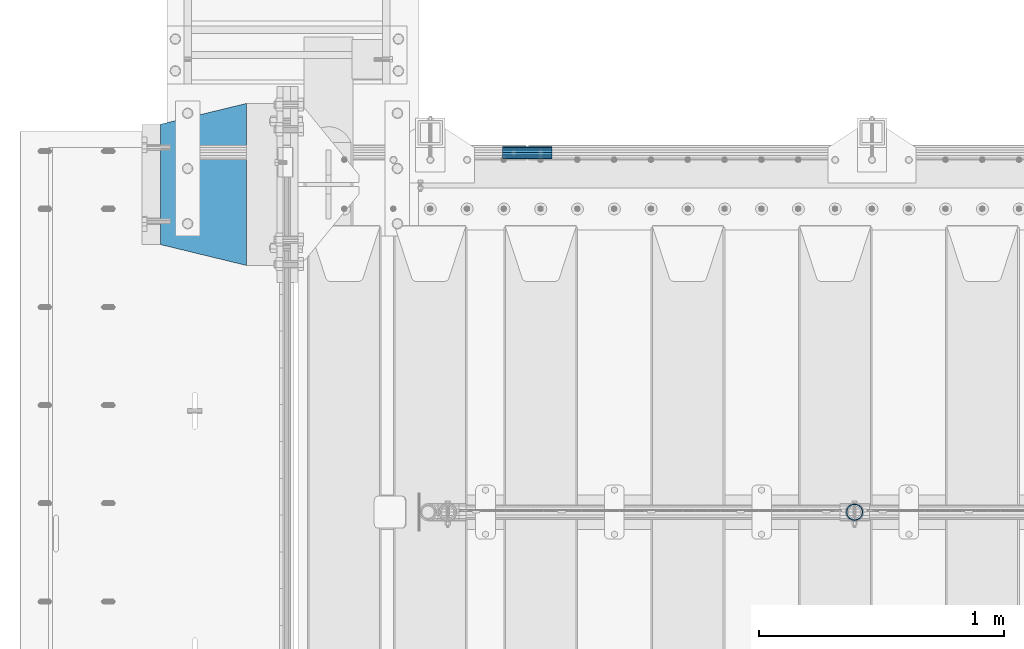
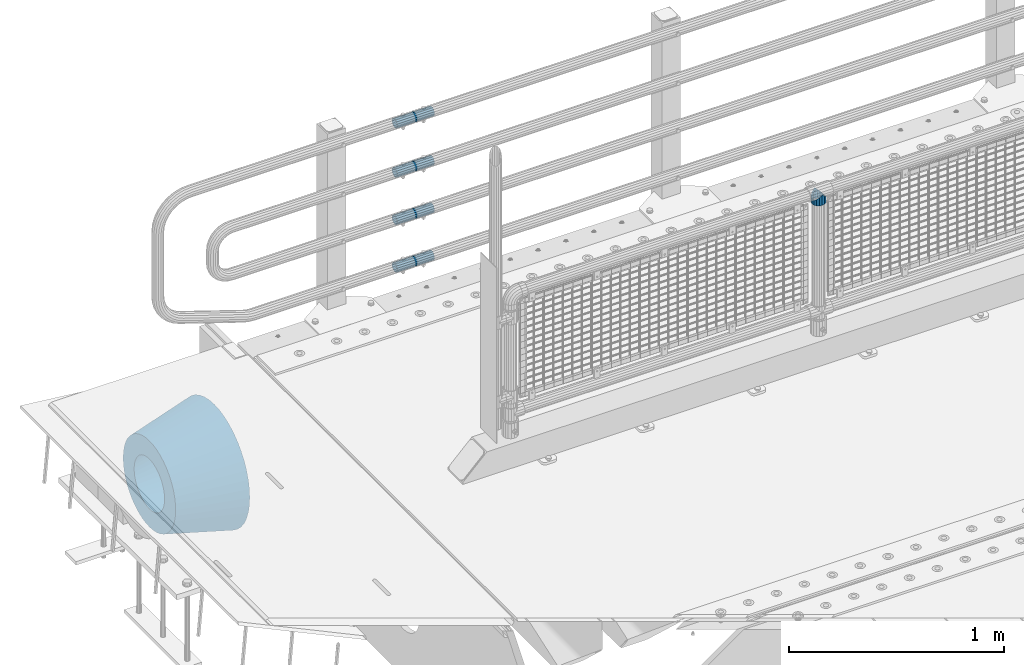
# One storey, part 137 of 219: 6 beams.
"""IFC2X3 building model written with IfcOpenShell, lengths in millimetres."""

from ifc_helpers import new_model, si_unit, frame, origin_with_axes, place, context, subcontext, project, spatial, faceted_brep, material, type_object, element, save


model = new_model("IFC2X3")

# Units and contexts
model_context = context("Model", 3, precision=1e-05, world=origin_with_axes())
body_context = subcontext(model_context, "Body", "Model", "MODEL_VIEW")
ifc_project = project(units=[si_unit("LENGTHUNIT", "METRE", prefix="MILLI"), si_unit("AREAUNIT", "SQUARE_METRE"), si_unit("VOLUMEUNIT", "CUBIC_METRE"), si_unit("MASSUNIT", "GRAM", prefix="KILO"), si_unit("TIMEUNIT", "SECOND"), si_unit("PLANEANGLEUNIT", "RADIAN"), si_unit("SOLIDANGLEUNIT", "STERADIAN"), si_unit("THERMODYNAMICTEMPERATUREUNIT", "DEGREE_CELSIUS"), si_unit("LUMINOUSINTENSITYUNIT", "LUMEN")], contexts=[model_context])

# Site, building, storey
site_placement = place(None, origin_with_axes())
site = spatial("IfcSite", under=ifc_project, at=site_placement, CompositionType="ELEMENT")
building_placement = place(site_placement, origin_with_axes())
building = spatial("IfcBuilding", under=site, at=building_placement, Name="Standard", CompositionType="ELEMENT")
storey_placement = place(building_placement, origin_with_axes())
storey = spatial("IfcBuildingStorey", under=building, at=storey_placement, Name="Undefined", CompositionType="ELEMENT", Elevation=0.0)

# Beams
ifc_material_1 = material(Name="Misc_Undefined")
beam_type_1 = type_object("IfcBeamType", PredefinedType="NOTDEFINED")
beam_1_placement = place(storey_placement, frame((2279.0, 31664.5, 969.849999999999), z_axis=(0.0, 1.0, 0.0), x_axis=(0.0, 0.0, -1.0)))
element("IfcBeam", 1, at=beam_1_placement, inside=storey, type_object=beam_type_1, material=ifc_material_1, context=body_context, shape_type="Brep", body=[
    faceted_brep([(0.0, 0.0, 35.1500000000015), (13.4513226476338, 13.4513226476329, 32.4743655677703), (13.4513226476338, -13.4513226476329, 32.4743655677703), (24.8548033587067, -16.3810424080013, -24.8548033587067), (24.8548033587067, -24.8548033587072, -24.8548033587067), (32.4743655677721, -32.4743655677717, -13.4513226476338), (32.4743655677721, -26.8123795176712, -13.4513226476338), (27.1226768591077, -21.4606908090117, -21.46069080901), (0.0, 0.0, -35.1500000000015), (13.4513226476338, -13.4513226476329, -32.4743655677703), (13.4513226476338, 13.4513226476329, -32.4743655677703), (20.0882031229739, -11.6144421722805, -28.0397438117179), (16.6306603983649, 0.0, -30.3499999999985), (20.0882031229739, 11.6144421722805, -28.0397438117179), (24.8548033587067, 16.3810424080013, -24.8548033587067), (24.8548033587067, 24.8548033587072, -24.8548033587067), (27.1226768591077, 21.4606908090117, -21.46069080901), (32.4743655677721, 26.8123795176755, -13.4513226476338), (32.4743655677721, 32.4743655677717, -13.4513226476338), (32.8397438117172, 28.0397438117175, -11.614442172282), (35.1499999999996, 30.35, 0.0), (35.1499999999996, 35.15, 0.0), (32.8397438117172, 28.0397438117175, 11.614442172282), (32.4743655677721, 26.8123795176755, 13.4513226476338), (32.4743655677721, 32.4743655677717, 13.4513226476338), (27.1226768591096, 21.4606908090117, 21.46069080901), (24.8548033587067, 16.3810424080078, 24.8548033587067), (24.8548033587067, 24.8548033587072, 24.8548033587067), (20.0882031229849, 11.6144421722805, 28.0397438117179), (16.6306603983739, 0.0, 30.3499999999985), (20.0882031229849, -11.6144421722805, 28.0397438117179), (24.8548033587067, -16.3810424080013, 24.8548033587067), (24.8548033587067, -24.8548033587072, 24.8548033587067), (27.1226768591096, -21.4606908090117, 21.46069080901), (32.4743655677721, -26.8123795176755, 13.4513226476338), (32.4743655677721, -32.4743655677717, 13.4513226476338), (32.8397438117172, -28.0397438117175, 11.614442172282), (35.1499999999996, -30.35, 0.0), (35.1499999999996, -35.15, 0.0), (32.8397438117172, -28.0397438117175, -11.614442172282), (60.1499999999996, -24.8548033587072, -24.8548033587067), (60.1499999999996, -32.4743655677717, -13.4513226476338), (60.1499999999996, -13.4513226476329, -32.4743655677703), (60.1499999999996, 0.0, -35.1500000000015), (60.1499999999996, 13.4513226476329, -32.4743655677703), (60.1499999999996, 24.8548033587072, -24.8548033587067), (60.1499999999996, 32.4743655677717, -13.4513226476338), (60.1499999999996, 35.15, 0.0), (60.1499999999996, 32.4743655677717, 13.4513226476338), (60.1499999999996, 24.8548033587072, 24.8548033587067), (60.1499999999996, 13.4513226476329, 32.4743655677703), (60.1499999999996, 0.0, 35.1500000000015), (60.1499999999996, -13.4513226476329, 32.4743655677703), (60.1499999999996, -24.8548033587072, 24.8548033587067), (60.1499999999996, -32.4743655677717, 13.4513226476338), (60.1499999999996, -35.15, 0.0), (60.1499999999996, -21.4606908090117, 21.46069080901), (60.1499999999996, -11.6144421722805, 28.0397438117179), (60.1499999999996, 0.0, 30.3499999999985), (60.1499999999996, 11.6144421722805, 28.0397438117179), (60.1499999999996, 21.4606908090117, 21.46069080901), (60.1499999999996, 28.0397438117175, 11.614442172282), (60.1499999999996, 30.35, 0.0), (60.1499999999996, 28.0397438117175, -11.614442172282), (60.1499999999996, 21.4606908090117, -21.46069080901), (60.1499999999996, 11.6144421722805, -28.0397438117179), (60.1499999999996, 0.0, -30.3499999999985), (60.1499999999996, -11.6144421722805, -28.0397438117179), (60.1499999999996, -21.4606908090117, -21.46069080901), (60.1499999999996, -28.0397438117175, -11.614442172282), (60.1499999999996, -30.35, 0.0), (60.1499999999996, -28.0397438117175, 11.614442172282)], [[[0, 1, 2]], [[3, 4, 5, 6, 7]], [[8, 9, 10]], [[10, 9, 4, 3, 11, 12, 13, 14, 15]], [[15, 14, 16, 17, 18]], [[18, 17, 19, 20, 21]], [[21, 20, 22, 23, 24]], [[24, 23, 25, 26, 27]], [[27, 26, 28, 29, 30, 31, 32, 2, 1]], [[33, 34, 35, 32, 31]], [[36, 37, 38, 35, 34]], [[6, 5, 38, 37, 39]], [[40, 41, 5, 4]], [[42, 40, 4, 9]], [[43, 42, 9, 8]], [[44, 43, 8, 10]], [[45, 44, 10, 15]], [[46, 45, 15, 18]], [[47, 46, 18, 21]], [[48, 47, 21, 24]], [[49, 48, 24, 27]], [[50, 49, 27, 1]], [[51, 50, 1, 0]], [[52, 51, 0, 2]], [[53, 52, 2, 32]], [[54, 53, 32, 35]], [[55, 54, 35, 38]], [[41, 55, 38, 5]], [[40, 42, 43, 44, 45, 46, 47, 48, 49, 50, 51, 52, 53, 54, 55, 41], [56, 57, 58, 59, 60, 61, 62, 63, 64, 65, 66, 67, 68, 69, 70, 71]], [[71, 70, 37, 36]], [[56, 71, 36, 34, 33]], [[57, 56, 33, 31, 30]], [[58, 57, 30, 29]], [[59, 58, 29, 28]], [[25, 60, 59, 28, 26]], [[22, 61, 60, 25, 23]], [[62, 61, 22, 20]], [[63, 62, 20, 19]], [[64, 63, 19, 17, 16]], [[65, 64, 16, 14, 13]], [[66, 65, 13, 12]], [[67, 66, 12, 11]], [[7, 68, 67, 11, 3]], [[39, 69, 68, 7, 6]], [[70, 69, 39, 37]]]),
])
ifc_material_2 = material()
beam_type_2 = type_object("IfcBeamType", PredefinedType="NOTDEFINED")
beam_2_placement = place(storey_placement, frame((844.997502999948, 33129.8500000004, 149.849999999747), z_axis=(0.0, 0.0, 1.0), x_axis=(1.0, 0.0, 0.0)))
element("IfcBeam", 2, at=beam_2_placement, inside=storey, type_object=beam_type_2, material=ifc_material_2, context=body_context, shape_type="Brep", body=[
    faceted_brep([(0.0, -21.9000000000015, 0.0), (0.0, -20.232961761998, 8.38076716879547), (200.0, -20.232961761998, 8.38076716879547), (200.0, -21.9000000000015, 0.0), (0.0, -15.4856385079838, 15.4856385079854), (200.0, -15.4856385079838, 15.4856385079854), (0.0, -8.38076716879732, 20.2329617619972), (200.0, -8.38076716879732, 20.2329617619972), (0.0, 0.0, 21.9), (200.0, 0.0, 21.9), (0.0, 8.38076716879732, 20.2329617619972), (200.0, 8.38076716879732, 20.2329617619972), (0.0, 15.4856385079838, 15.4856385079854), (200.0, 15.4856385079838, 15.4856385079854), (0.0, 20.232961761998, 8.38076716879547), (200.0, 20.232961761998, 8.38076716879547), (0.0, 21.9000000000015, 0.0), (200.0, 21.9000000000015, 0.0), (0.0, 20.232961761998, -8.38076716879547), (200.0, 20.232961761998, -8.38076716879547), (0.0, 15.4856385079838, -15.4856385079854), (200.0, 15.4856385079838, -15.4856385079854), (0.0, 8.38076716879732, -20.2329617619972), (200.0, 8.38076716879732, -20.2329617619972), (0.0, 0.0, -21.9), (200.0, 0.0, -21.9), (0.0, -8.38076716879732, -20.2329617619972), (200.0, -8.38076716879732, -20.2329617619972), (0.0, -15.4856385079838, -15.4856385079854), (200.0, -15.4856385079838, -15.4856385079854), (0.0, -20.232961761998, -8.38076716879547), (200.0, -20.232961761998, -8.38076716879547), (0.0, -25.5, 0.0), (0.0, -23.5589280790373, -9.7584275253098), (200.0, -23.5589280790373, -9.7584275253098), (200.0, -25.5, 0.0), (0.0, -18.0312229202536, -18.031222920257), (200.0, -18.0312229202536, -18.031222920257), (0.0, -9.75842752531025, -23.5589280790378), (200.0, -9.75842752531025, -23.5589280790378), (0.0, 0.0, -25.5), (200.0, 0.0, -25.5), (0.0, 9.75842752531025, -23.5589280790378), (200.0, 9.75842752531025, -23.5589280790378), (0.0, 18.0312229202536, -18.031222920257), (200.0, 18.0312229202536, -18.031222920257), (0.0, 23.5589280790373, -9.7584275253098), (200.0, 23.5589280790373, -9.7584275253098), (0.0, 25.5, 0.0), (200.0, 25.5, 0.0), (0.0, 23.5589280790373, 9.7584275253098), (200.0, 23.5589280790373, 9.7584275253098), (0.0, 18.0312229202536, 18.031222920257), (200.0, 18.0312229202536, 18.031222920257), (0.0, 9.75842752531025, 23.5589280790378), (200.0, 9.75842752531025, 23.5589280790378), (0.0, 0.0, 25.5), (200.0, 0.0, 25.5), (0.0, -9.75842752531025, 23.5589280790378), (200.0, -9.75842752531025, 23.5589280790378), (0.0, -18.0312229202536, 18.031222920257), (200.0, -18.0312229202536, 18.031222920257), (0.0, -23.5589280790373, 9.7584275253098), (200.0, -23.5589280790373, 9.7584275253098)], [[[0, 1, 2, 3]], [[1, 4, 5, 2]], [[4, 6, 7, 5]], [[6, 8, 9, 7]], [[8, 10, 11, 9]], [[10, 12, 13, 11]], [[12, 14, 15, 13]], [[14, 16, 17, 15]], [[16, 18, 19, 17]], [[18, 20, 21, 19]], [[20, 22, 23, 21]], [[22, 24, 25, 23]], [[24, 26, 27, 25]], [[26, 28, 29, 27]], [[28, 30, 31, 29]], [[30, 0, 3, 31]], [[32, 33, 34, 35]], [[33, 36, 37, 34]], [[36, 38, 39, 37]], [[38, 40, 41, 39]], [[40, 42, 43, 41]], [[42, 44, 45, 43]], [[44, 46, 47, 45]], [[46, 48, 49, 47]], [[48, 50, 51, 49]], [[50, 52, 53, 51]], [[52, 54, 55, 53]], [[54, 56, 57, 55]], [[56, 58, 59, 57]], [[58, 60, 61, 59]], [[60, 62, 63, 61]], [[62, 32, 35, 63]], [[37, 39, 41, 43, 45, 47, 49, 51, 53, 55, 57, 59, 61, 63, 35, 34], [5, 7, 9, 11, 13, 15, 17, 19, 21, 23, 25, 27, 29, 31, 3, 2]], [[62, 60, 58, 56, 54, 52, 50, 48, 46, 44, 42, 40, 38, 36, 33, 32], [30, 28, 26, 24, 22, 20, 18, 16, 14, 12, 10, 8, 6, 4, 1, 0]]]),
])
beam_3_placement = place(storey_placement, frame((844.997502999948, 33129.8500000004, 420.149999999747), z_axis=(0.0, 0.0, 1.0), x_axis=(1.0, 0.0, 0.0)))
element("IfcBeam", 3, at=beam_3_placement, inside=storey, type_object=beam_type_2, material=ifc_material_2, context=body_context, shape_type="Brep", body=[
    faceted_brep([(0.0, -21.9000000000015, 0.0), (0.0, -20.232961761998, 8.38076716879547), (200.0, -20.232961761998, 8.38076716879547), (200.0, -21.9000000000015, 0.0), (0.0, -15.4856385079838, 15.4856385079854), (200.0, -15.4856385079838, 15.4856385079854), (0.0, -8.38076716879732, 20.2329617619972), (200.0, -8.38076716879732, 20.2329617619972), (0.0, 0.0, 21.9), (200.0, 0.0, 21.9), (0.0, 8.38076716879732, 20.2329617619972), (200.0, 8.38076716879732, 20.2329617619972), (0.0, 15.4856385079838, 15.4856385079854), (200.0, 15.4856385079838, 15.4856385079854), (0.0, 20.232961761998, 8.38076716879547), (200.0, 20.232961761998, 8.38076716879547), (0.0, 21.9000000000015, 0.0), (200.0, 21.9000000000015, 0.0), (0.0, 20.232961761998, -8.38076716879547), (200.0, 20.232961761998, -8.38076716879547), (0.0, 15.4856385079838, -15.4856385079854), (200.0, 15.4856385079838, -15.4856385079854), (0.0, 8.38076716879732, -20.2329617619972), (200.0, 8.38076716879732, -20.2329617619972), (0.0, 0.0, -21.9), (200.0, 0.0, -21.9), (0.0, -8.38076716879732, -20.2329617619972), (200.0, -8.38076716879732, -20.2329617619972), (0.0, -15.4856385079838, -15.4856385079854), (200.0, -15.4856385079838, -15.4856385079854), (0.0, -20.232961761998, -8.38076716879547), (200.0, -20.232961761998, -8.38076716879547), (0.0, -25.5, 0.0), (0.0, -23.5589280790373, -9.7584275253098), (200.0, -23.5589280790373, -9.7584275253098), (200.0, -25.5, 0.0), (0.0, -18.0312229202536, -18.031222920257), (200.0, -18.0312229202536, -18.031222920257), (0.0, -9.75842752531025, -23.5589280790378), (200.0, -9.75842752531025, -23.5589280790378), (0.0, 0.0, -25.5), (200.0, 0.0, -25.5), (0.0, 9.75842752531025, -23.5589280790378), (200.0, 9.75842752531025, -23.5589280790378), (0.0, 18.0312229202536, -18.031222920257), (200.0, 18.0312229202536, -18.031222920257), (0.0, 23.5589280790373, -9.7584275253098), (200.0, 23.5589280790373, -9.7584275253098), (0.0, 25.5, 0.0), (200.0, 25.5, 0.0), (0.0, 23.5589280790373, 9.7584275253098), (200.0, 23.5589280790373, 9.7584275253098), (0.0, 18.0312229202536, 18.031222920257), (200.0, 18.0312229202536, 18.031222920257), (0.0, 9.75842752531025, 23.5589280790378), (200.0, 9.75842752531025, 23.5589280790378), (0.0, 0.0, 25.5), (200.0, 0.0, 25.5), (0.0, -9.75842752531025, 23.5589280790378), (200.0, -9.75842752531025, 23.5589280790378), (0.0, -18.0312229202536, 18.031222920257), (200.0, -18.0312229202536, 18.031222920257), (0.0, -23.5589280790373, 9.7584275253098), (200.0, -23.5589280790373, 9.7584275253098)], [[[0, 1, 2, 3]], [[1, 4, 5, 2]], [[4, 6, 7, 5]], [[6, 8, 9, 7]], [[8, 10, 11, 9]], [[10, 12, 13, 11]], [[12, 14, 15, 13]], [[14, 16, 17, 15]], [[16, 18, 19, 17]], [[18, 20, 21, 19]], [[20, 22, 23, 21]], [[22, 24, 25, 23]], [[24, 26, 27, 25]], [[26, 28, 29, 27]], [[28, 30, 31, 29]], [[30, 0, 3, 31]], [[32, 33, 34, 35]], [[33, 36, 37, 34]], [[36, 38, 39, 37]], [[38, 40, 41, 39]], [[40, 42, 43, 41]], [[42, 44, 45, 43]], [[44, 46, 47, 45]], [[46, 48, 49, 47]], [[48, 50, 51, 49]], [[50, 52, 53, 51]], [[52, 54, 55, 53]], [[54, 56, 57, 55]], [[56, 58, 59, 57]], [[58, 60, 61, 59]], [[60, 62, 63, 61]], [[62, 32, 35, 63]], [[37, 39, 41, 43, 45, 47, 49, 51, 53, 55, 57, 59, 61, 63, 35, 34], [5, 7, 9, 11, 13, 15, 17, 19, 21, 23, 25, 27, 29, 31, 3, 2]], [[62, 60, 58, 56, 54, 52, 50, 48, 46, 44, 42, 40, 38, 36, 33, 32], [30, 28, 26, 24, 22, 20, 18, 16, 14, 12, 10, 8, 6, 4, 1, 0]]]),
])
beam_4_placement = place(storey_placement, frame((844.997502999948, 33129.8500000004, 969.849999999747), z_axis=(0.0, 0.0, 1.0), x_axis=(1.0, 0.0, 0.0)))
element("IfcBeam", 4, at=beam_4_placement, inside=storey, type_object=beam_type_2, material=ifc_material_2, context=body_context, shape_type="Brep", body=[
    faceted_brep([(0.0, -21.9000000000015, 0.0), (0.0, -20.232961761998, 8.38076716879547), (200.0, -20.232961761998, 8.38076716879547), (200.0, -21.9000000000015, 0.0), (0.0, -15.4856385079838, 15.4856385079854), (200.0, -15.4856385079838, 15.4856385079854), (0.0, -8.38076716879732, 20.2329617619972), (200.0, -8.38076716879732, 20.2329617619972), (0.0, 0.0, 21.9), (200.0, 0.0, 21.9), (0.0, 8.38076716879732, 20.2329617619972), (200.0, 8.38076716879732, 20.2329617619972), (0.0, 15.4856385079838, 15.4856385079854), (200.0, 15.4856385079838, 15.4856385079854), (0.0, 20.232961761998, 8.38076716879547), (200.0, 20.232961761998, 8.38076716879547), (0.0, 21.9000000000015, 0.0), (200.0, 21.9000000000015, 0.0), (0.0, 20.232961761998, -8.38076716879547), (200.0, 20.232961761998, -8.38076716879547), (0.0, 15.4856385079838, -15.4856385079854), (200.0, 15.4856385079838, -15.4856385079854), (0.0, 8.38076716879732, -20.2329617619972), (200.0, 8.38076716879732, -20.2329617619972), (0.0, 0.0, -21.9), (200.0, 0.0, -21.9), (0.0, -8.38076716879732, -20.2329617619972), (200.0, -8.38076716879732, -20.2329617619972), (0.0, -15.4856385079838, -15.4856385079854), (200.0, -15.4856385079838, -15.4856385079854), (0.0, -20.232961761998, -8.38076716879547), (200.0, -20.232961761998, -8.38076716879547), (0.0, -25.5, 0.0), (0.0, -23.5589280790373, -9.7584275253098), (200.0, -23.5589280790373, -9.7584275253098), (200.0, -25.5, 0.0), (0.0, -18.0312229202536, -18.031222920257), (200.0, -18.0312229202536, -18.031222920257), (0.0, -9.75842752531025, -23.5589280790378), (200.0, -9.75842752531025, -23.5589280790378), (0.0, 0.0, -25.5), (200.0, 0.0, -25.5), (0.0, 9.75842752531025, -23.5589280790378), (200.0, 9.75842752531025, -23.5589280790378), (0.0, 18.0312229202536, -18.031222920257), (200.0, 18.0312229202536, -18.031222920257), (0.0, 23.5589280790373, -9.7584275253098), (200.0, 23.5589280790373, -9.7584275253098), (0.0, 25.5, 0.0), (200.0, 25.5, 0.0), (0.0, 23.5589280790373, 9.7584275253098), (200.0, 23.5589280790373, 9.7584275253098), (0.0, 18.0312229202536, 18.031222920257), (200.0, 18.0312229202536, 18.031222920257), (0.0, 9.75842752531025, 23.5589280790378), (200.0, 9.75842752531025, 23.5589280790378), (0.0, 0.0, 25.5), (200.0, 0.0, 25.5), (0.0, -9.75842752531025, 23.5589280790378), (200.0, -9.75842752531025, 23.5589280790378), (0.0, -18.0312229202536, 18.031222920257), (200.0, -18.0312229202536, 18.031222920257), (0.0, -23.5589280790373, 9.7584275253098), (200.0, -23.5589280790373, 9.7584275253098)], [[[0, 1, 2, 3]], [[1, 4, 5, 2]], [[4, 6, 7, 5]], [[6, 8, 9, 7]], [[8, 10, 11, 9]], [[10, 12, 13, 11]], [[12, 14, 15, 13]], [[14, 16, 17, 15]], [[16, 18, 19, 17]], [[18, 20, 21, 19]], [[20, 22, 23, 21]], [[22, 24, 25, 23]], [[24, 26, 27, 25]], [[26, 28, 29, 27]], [[28, 30, 31, 29]], [[30, 0, 3, 31]], [[32, 33, 34, 35]], [[33, 36, 37, 34]], [[36, 38, 39, 37]], [[38, 40, 41, 39]], [[40, 42, 43, 41]], [[42, 44, 45, 43]], [[44, 46, 47, 45]], [[46, 48, 49, 47]], [[48, 50, 51, 49]], [[50, 52, 53, 51]], [[52, 54, 55, 53]], [[54, 56, 57, 55]], [[56, 58, 59, 57]], [[58, 60, 61, 59]], [[60, 62, 63, 61]], [[62, 32, 35, 63]], [[37, 39, 41, 43, 45, 47, 49, 51, 53, 55, 57, 59, 61, 63, 35, 34], [5, 7, 9, 11, 13, 15, 17, 19, 21, 23, 25, 27, 29, 31, 3, 2]], [[62, 60, 58, 56, 54, 52, 50, 48, 46, 44, 42, 40, 38, 36, 33, 32], [30, 28, 26, 24, 22, 20, 18, 16, 14, 12, 10, 8, 6, 4, 1, 0]]]),
])
beam_5_placement = place(storey_placement, frame((844.997502999948, 33129.8500000004, 689.849999999747), z_axis=(0.0, 0.0, 1.0), x_axis=(1.0, 0.0, 0.0)))
element("IfcBeam", 5, at=beam_5_placement, inside=storey, type_object=beam_type_2, material=ifc_material_2, context=body_context, shape_type="Brep", body=[
    faceted_brep([(0.0, -21.9000000000015, 0.0), (0.0, -20.232961761998, 8.38076716879547), (200.0, -20.232961761998, 8.38076716879547), (200.0, -21.9000000000015, 0.0), (0.0, -15.4856385079838, 15.4856385079854), (200.0, -15.4856385079838, 15.4856385079854), (0.0, -8.38076716879732, 20.2329617619972), (200.0, -8.38076716879732, 20.2329617619972), (0.0, 0.0, 21.9), (200.0, 0.0, 21.9), (0.0, 8.38076716879732, 20.2329617619972), (200.0, 8.38076716879732, 20.2329617619972), (0.0, 15.4856385079838, 15.4856385079854), (200.0, 15.4856385079838, 15.4856385079854), (0.0, 20.232961761998, 8.38076716879547), (200.0, 20.232961761998, 8.38076716879547), (0.0, 21.9000000000015, 0.0), (200.0, 21.9000000000015, 0.0), (0.0, 20.232961761998, -8.38076716879547), (200.0, 20.232961761998, -8.38076716879547), (0.0, 15.4856385079838, -15.4856385079854), (200.0, 15.4856385079838, -15.4856385079854), (0.0, 8.38076716879732, -20.2329617619972), (200.0, 8.38076716879732, -20.2329617619972), (0.0, 0.0, -21.9), (200.0, 0.0, -21.9), (0.0, -8.38076716879732, -20.2329617619972), (200.0, -8.38076716879732, -20.2329617619972), (0.0, -15.4856385079838, -15.4856385079854), (200.0, -15.4856385079838, -15.4856385079854), (0.0, -20.232961761998, -8.38076716879547), (200.0, -20.232961761998, -8.38076716879547), (0.0, -25.5, 0.0), (0.0, -23.5589280790373, -9.7584275253098), (200.0, -23.5589280790373, -9.7584275253098), (200.0, -25.5, 0.0), (0.0, -18.0312229202536, -18.031222920257), (200.0, -18.0312229202536, -18.031222920257), (0.0, -9.75842752531025, -23.5589280790378), (200.0, -9.75842752531025, -23.5589280790378), (0.0, 0.0, -25.5), (200.0, 0.0, -25.5), (0.0, 9.75842752531025, -23.5589280790378), (200.0, 9.75842752531025, -23.5589280790378), (0.0, 18.0312229202536, -18.031222920257), (200.0, 18.0312229202536, -18.031222920257), (0.0, 23.5589280790373, -9.7584275253098), (200.0, 23.5589280790373, -9.7584275253098), (0.0, 25.5, 0.0), (200.0, 25.5, 0.0), (0.0, 23.5589280790373, 9.7584275253098), (200.0, 23.5589280790373, 9.7584275253098), (0.0, 18.0312229202536, 18.031222920257), (200.0, 18.0312229202536, 18.031222920257), (0.0, 9.75842752531025, 23.5589280790378), (200.0, 9.75842752531025, 23.5589280790378), (0.0, 0.0, 25.5), (200.0, 0.0, 25.5), (0.0, -9.75842752531025, 23.5589280790378), (200.0, -9.75842752531025, 23.5589280790378), (0.0, -18.0312229202536, 18.031222920257), (200.0, -18.0312229202536, 18.031222920257), (0.0, -23.5589280790373, 9.7584275253098), (200.0, -23.5589280790373, 9.7584275253098)], [[[0, 1, 2, 3]], [[1, 4, 5, 2]], [[4, 6, 7, 5]], [[6, 8, 9, 7]], [[8, 10, 11, 9]], [[10, 12, 13, 11]], [[12, 14, 15, 13]], [[14, 16, 17, 15]], [[16, 18, 19, 17]], [[18, 20, 21, 19]], [[20, 22, 23, 21]], [[22, 24, 25, 23]], [[24, 26, 27, 25]], [[26, 28, 29, 27]], [[28, 30, 31, 29]], [[30, 0, 3, 31]], [[32, 33, 34, 35]], [[33, 36, 37, 34]], [[36, 38, 39, 37]], [[38, 40, 41, 39]], [[40, 42, 43, 41]], [[42, 44, 45, 43]], [[44, 46, 47, 45]], [[46, 48, 49, 47]], [[48, 50, 51, 49]], [[50, 52, 53, 51]], [[52, 54, 55, 53]], [[54, 56, 57, 55]], [[56, 58, 59, 57]], [[58, 60, 61, 59]], [[60, 62, 63, 61]], [[62, 32, 35, 63]], [[37, 39, 41, 43, 45, 47, 49, 51, 53, 55, 57, 59, 61, 63, 35, 34], [5, 7, 9, 11, 13, 15, 17, 19, 21, 23, 25, 27, 29, 31, 3, 2]], [[62, 60, 58, 56, 54, 52, 50, 48, 46, 44, 42, 40, 38, 36, 33, 32], [30, 28, 26, 24, 22, 20, 18, 16, 14, 12, 10, 8, 6, 4, 1, 0]]]),
])
ifc_material_3 = material(Name="SCN-500-E2")
beam_type_3 = type_object("IfcBeamType", PredefinedType="NOTDEFINED")
beam_6_placement = place(storey_placement, frame((-199.999999999991, 33000.0, -515.0), z_axis=(0.0, 0.0, 1.0), x_axis=(-1.0, 0.0, 0.0)))
element("IfcBeam", 6, at=beam_6_placement, inside=storey, type_object=beam_type_3, material=ifc_material_3, context=body_context, shape_type="Brep", body=[
    faceted_brep([(0.0, -330.0, 0.0), (0.0, -326.641075820706, -46.9638966301842), (350.0, -242.506253260828, -34.8671353769549), (350.0, -245.0, 0.0), (0.0, -316.632681292787, -92.9717437576718), (350.0, -235.075778535553, -69.0244764261503), (0.0, -300.178558466992, -137.086954290623), (350.0, -222.859838861856, -101.776678185462), (0.0, -277.613665834288, -178.411469760347), (350.0, -206.107115543637, -132.457000276621), (0.0, -249.397359536903, -216.104042201944), (350.0, -185.158645716794, -160.440879816595), (0.0, -216.104042201943, -249.397359536905), (350.0, -160.440879816597, -185.158645716793), (0.0, -178.411469760344, -277.61366583429), (350.0, -132.45700027662, -206.107115543639), (0.0, -137.086954290622, -300.178558466991), (350.0, -101.776678185459, -222.859838861857), (0.0, -92.9717437576692, -316.632681292784), (350.0, -69.0244764261515, -235.075778535552), (0.0, -46.9638966301864, -326.641075820708), (350.0, -34.8671353769532, -242.506253260829), (0.0, 0.0, -330.0), (350.0, 0.0, -245.0), (0.0, 46.9638966301864, -326.641075820708), (350.0, 34.8671353769532, -242.506253260829), (0.0, 92.9717437576692, -316.632681292784), (350.0, 69.0244764261515, -235.075778535552), (0.0, 137.086954290622, -300.178558466991), (350.0, 101.776678185459, -222.859838861857), (0.0, 178.411469760344, -277.61366583429), (350.0, 132.45700027662, -206.107115543639), (0.0, 216.104042201943, -249.397359536905), (350.0, 160.440879816597, -185.158645716793), (0.0, 249.397359536906, -216.104042201944), (350.0, 185.158645716794, -160.440879816595), (0.0, 277.613665834291, -178.411469760347), (350.0, 206.107115543637, -132.457000276621), (0.0, 300.178558466992, -137.086954290623), (350.0, 222.859838861856, -101.776678185462), (0.0, 316.632681292784, -92.9717437576717), (350.0, 235.075778535553, -69.0244764261502), (0.0, 326.641075820709, -46.9638966301841), (350.0, 242.506253260828, -34.8671353769548), (0.0, 330.0, 0.0), (350.0, 245.0, 0.0), (0.0, 326.641075820709, 46.9638966301841), (350.0, 242.506253260828, 34.8671353769549), (0.0, 316.632681292784, 92.9717437576718), (350.0, 235.075778535553, 69.0244764261503), (0.0, 300.178558466992, 137.086954290622), (350.0, 222.859838861856, 101.776678185462), (0.0, 277.613665834291, 178.411469760347), (350.0, 206.107115543637, 132.457000276621), (0.0, 249.397359536906, 216.104042201944), (350.0, 185.158645716794, 160.440879816595), (0.0, 216.104042201943, 249.397359536905), (350.0, 160.440879816597, 185.158645716793), (0.0, 178.411469760344, 277.61366583429), (350.0, 132.45700027662, 206.107115543639), (0.0, 137.086954290622, 300.178558466991), (350.0, 101.776678185459, 222.859838861857), (0.0, 92.9717437576692, 316.632681292784), (350.0, 69.0244764261515, 235.075778535552), (0.0, 46.9638966301864, 326.641075820708), (350.0, 34.8671353769532, 242.506253260829), (0.0, 0.0, 330.0), (350.0, 0.0, 245.0), (0.0, -46.9638966301864, 326.641075820708), (350.0, -34.8671353769532, 242.506253260829), (0.0, -92.9717437576692, 316.632681292784), (350.0, -69.0244764261515, 235.075778535552), (0.0, -137.086954290622, 300.178558466991), (350.0, -101.776678185459, 222.859838861857), (0.0, -178.411469760344, 277.61366583429), (350.0, -132.45700027662, 206.107115543639), (0.0, -216.104042201943, 249.397359536905), (350.0, -160.440879816597, 185.158645716793), (0.0, -249.397359536903, 216.104042201944), (350.0, -185.158645716794, 160.440879816595), (0.0, -277.613665834288, 178.411469760347), (350.0, -206.107115543637, 132.457000276621), (0.0, -300.178558466992, 137.086954290623), (350.0, -222.859838861856, 101.776678185462), (0.0, -316.632681292787, 92.9717437576718), (350.0, -235.075778535553, 69.0244764261503), (0.0, -326.641075820706, 46.9638966301841), (350.0, -242.506253260828, 34.8671353769549), (0.0, -227.093265923133, 0.0), (0.0, -224.781783917482, 32.3187414128026), (350.0, -140.646961357605, 20.2219801595734), (350.0, -142.093265923133, 0.0), (0.0, -217.894393008413, 63.9795664499945), (350.0, -136.337490251179, 40.032299118473), (0.0, -206.571300613236, 94.3379520160985), (350.0, -129.252581008099, 59.0276759109381), (0.0, -191.043012240007, 122.775888927343), (350.0, -119.536461949356, 76.8214194436173), (0.0, -171.625639060127, 148.714462796454), (350.0, -107.386925240011, 93.0513004111044), (0.0, -148.714462796452, 171.625639060125), (350.0, -93.0513004111053, 107.386925240013), (0.0, -122.775888927346, 191.043012240005), (350.0, -76.821419443615, 119.536461949355), (0.0, -94.3379520160961, 206.571300613232), (350.0, -59.0276759109402, 129.252581008098), (0.0, -63.9795664499979, 217.894393008413), (350.0, -40.032299118473, 136.337490251181), (0.0, -32.3187414128042, 224.781783917484), (350.0, -20.2219801595711, 140.646961357605), (0.0, 0.0, 227.093265923131), (350.0, 0.0, 142.093265923131), (0.0, 32.3187414128042, 224.781783917484), (350.0, 20.2219801595711, 140.646961357605), (0.0, 63.9795664499979, 217.894393008413), (350.0, 40.032299118473, 136.337490251181), (0.0, 94.3379520160961, 206.571300613232), (350.0, 59.0276759109402, 129.252581008098), (0.0, 122.775888927346, 191.043012240005), (350.0, 76.821419443615, 119.536461949355), (0.0, 148.714462796452, 171.625639060125), (350.0, 93.0513004111053, 107.386925240013), (0.0, 171.625639060127, 148.714462796454), (350.0, 107.386925240011, 93.0513004111044), (0.0, 191.043012240007, 122.775888927343), (350.0, 119.536461949356, 76.8214194436174), (0.0, 206.571300613236, 94.3379520160985), (350.0, 129.252581008099, 59.0276759109382), (0.0, 217.894393008413, 63.9795664499945), (350.0, 136.337490251179, 40.032299118473), (0.0, 224.781783917482, 32.3187414128025), (350.0, 140.646961357605, 20.2219801595733), (0.0, 227.093265923133, 0.0), (350.0, 142.093265923133, 0.0), (0.0, 224.781783917482, -32.3187414128026), (350.0, 140.646961357605, -20.2219801595734), (0.0, 217.894393008413, -63.9795664499945), (350.0, 136.337490251179, -40.032299118473), (0.0, 206.571300613236, -94.3379520160985), (350.0, 129.252581008099, -59.0276759109381), (0.0, 191.043012240007, -122.775888927343), (350.0, 119.536461949356, -76.8214194436174), (0.0, 171.625639060127, -148.714462796454), (350.0, 107.386925240011, -93.0513004111044), (0.0, 148.714462796452, -171.625639060125), (350.0, 93.0513004111053, -107.386925240013), (0.0, 122.775888927346, -191.043012240005), (350.0, 76.821419443615, -119.536461949355), (0.0, 94.3379520160961, -206.571300613232), (350.0, 59.0276759109402, -129.252581008098), (0.0, 63.9795664499979, -217.894393008413), (350.0, 40.032299118473, -136.337490251181), (0.0, 32.3187414128042, -224.781783917484), (350.0, 20.2219801595711, -140.646961357605), (0.0, 0.0, -227.093265923131), (350.0, 0.0, -142.093265923131), (0.0, -32.3187414128042, -224.781783917484), (350.0, -20.2219801595711, -140.646961357605), (0.0, -63.9795664499979, -217.894393008413), (350.0, -40.032299118473, -136.337490251181), (0.0, -94.3379520160961, -206.571300613232), (350.0, -59.0276759109402, -129.252581008098), (0.0, -122.775888927346, -191.043012240005), (350.0, -76.821419443615, -119.536461949355), (0.0, -148.714462796452, -171.625639060125), (350.0, -93.0513004111053, -107.386925240013), (0.0, -171.625639060127, -148.714462796454), (350.0, -107.386925240011, -93.0513004111044), (0.0, -191.043012240007, -122.775888927343), (350.0, -119.536461949356, -76.8214194436174), (0.0, -206.571300613236, -94.3379520160985), (350.0, -129.252581008099, -59.0276759109381), (0.0, -217.894393008413, -63.9795664499945), (350.0, -136.337490251179, -40.032299118473), (0.0, -224.781783917482, -32.3187414128026), (350.0, -140.646961357605, -20.2219801595734)], [[[0, 1, 2, 3]], [[1, 4, 5, 2]], [[4, 6, 7, 5]], [[6, 8, 9, 7]], [[8, 10, 11, 9]], [[10, 12, 13, 11]], [[12, 14, 15, 13]], [[14, 16, 17, 15]], [[16, 18, 19, 17]], [[18, 20, 21, 19]], [[20, 22, 23, 21]], [[22, 24, 25, 23]], [[24, 26, 27, 25]], [[26, 28, 29, 27]], [[28, 30, 31, 29]], [[30, 32, 33, 31]], [[32, 34, 35, 33]], [[34, 36, 37, 35]], [[36, 38, 39, 37]], [[38, 40, 41, 39]], [[40, 42, 43, 41]], [[42, 44, 45, 43]], [[44, 46, 47, 45]], [[46, 48, 49, 47]], [[48, 50, 51, 49]], [[50, 52, 53, 51]], [[52, 54, 55, 53]], [[54, 56, 57, 55]], [[56, 58, 59, 57]], [[58, 60, 61, 59]], [[60, 62, 63, 61]], [[62, 64, 65, 63]], [[64, 66, 67, 65]], [[66, 68, 69, 67]], [[68, 70, 71, 69]], [[70, 72, 73, 71]], [[72, 74, 75, 73]], [[74, 76, 77, 75]], [[76, 78, 79, 77]], [[78, 80, 81, 79]], [[80, 82, 83, 81]], [[82, 84, 85, 83]], [[84, 86, 87, 85]], [[86, 0, 3, 87]], [[88, 89, 90, 91]], [[89, 92, 93, 90]], [[92, 94, 95, 93]], [[94, 96, 97, 95]], [[96, 98, 99, 97]], [[98, 100, 101, 99]], [[100, 102, 103, 101]], [[102, 104, 105, 103]], [[104, 106, 107, 105]], [[106, 108, 109, 107]], [[108, 110, 111, 109]], [[110, 112, 113, 111]], [[112, 114, 115, 113]], [[114, 116, 117, 115]], [[116, 118, 119, 117]], [[118, 120, 121, 119]], [[120, 122, 123, 121]], [[122, 124, 125, 123]], [[124, 126, 127, 125]], [[126, 128, 129, 127]], [[128, 130, 131, 129]], [[130, 132, 133, 131]], [[132, 134, 135, 133]], [[134, 136, 137, 135]], [[136, 138, 139, 137]], [[138, 140, 141, 139]], [[140, 142, 143, 141]], [[142, 144, 145, 143]], [[144, 146, 147, 145]], [[146, 148, 149, 147]], [[148, 150, 151, 149]], [[150, 152, 153, 151]], [[152, 154, 155, 153]], [[154, 156, 157, 155]], [[156, 158, 159, 157]], [[158, 160, 161, 159]], [[160, 162, 163, 161]], [[162, 164, 165, 163]], [[164, 166, 167, 165]], [[166, 168, 169, 167]], [[168, 170, 171, 169]], [[170, 172, 173, 171]], [[172, 174, 175, 173]], [[174, 88, 91, 175]], [[5, 7, 9, 11, 13, 15, 17, 19, 21, 23, 25, 27, 29, 31, 33, 35, 37, 39, 41, 43, 45, 47, 49, 51, 53, 55, 57, 59, 61, 63, 65, 67, 69, 71, 73, 75, 77, 79, 81, 83, 85, 87, 3, 2], [93, 95, 97, 99, 101, 103, 105, 107, 109, 111, 113, 115, 117, 119, 121, 123, 125, 127, 129, 131, 133, 135, 137, 139, 141, 143, 145, 147, 149, 151, 153, 155, 157, 159, 161, 163, 165, 167, 169, 171, 173, 175, 91, 90]], [[86, 84, 82, 80, 78, 76, 74, 72, 70, 68, 66, 64, 62, 60, 58, 56, 54, 52, 50, 48, 46, 44, 42, 40, 38, 36, 34, 32, 30, 28, 26, 24, 22, 20, 18, 16, 14, 12, 10, 8, 6, 4, 1, 0], [174, 172, 170, 168, 166, 164, 162, 160, 158, 156, 154, 152, 150, 148, 146, 144, 142, 140, 138, 136, 134, 132, 130, 128, 126, 124, 122, 120, 118, 116, 114, 112, 110, 108, 106, 104, 102, 100, 98, 96, 94, 92, 89, 88]]]),
])

save(model, "model.ifc")
